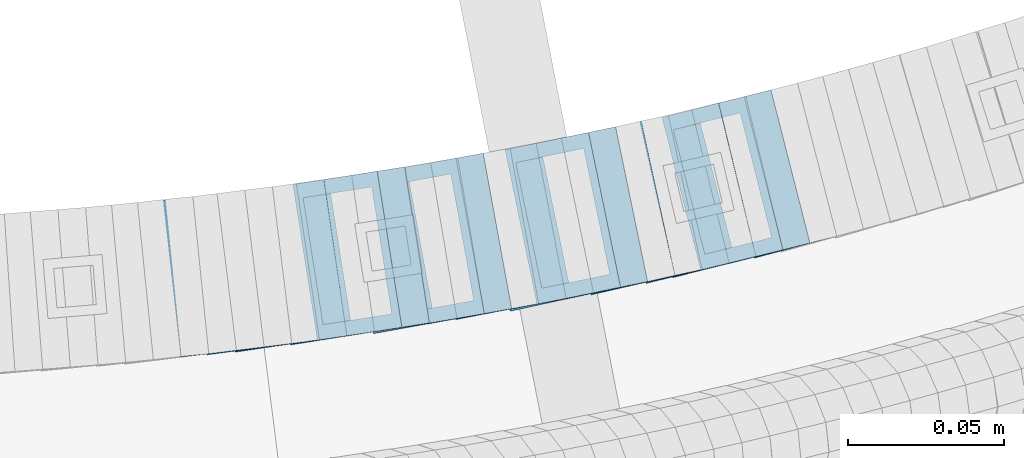
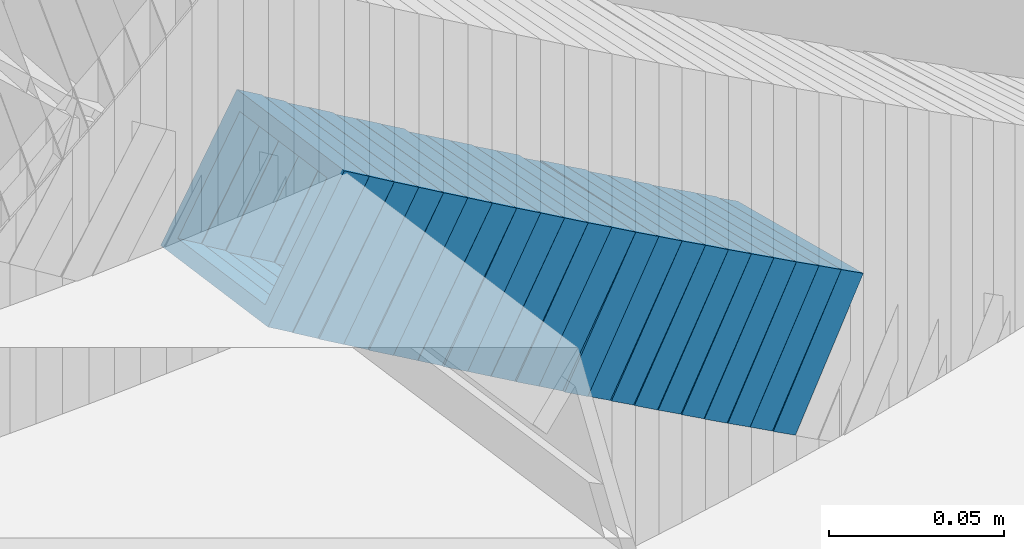
# One storey, part 711 of 975: 22 members.
"""IFC2X3 building model written with IfcOpenShell, lengths in millimetres."""

from ifc_helpers import new_model, si_unit, frame, origin_with_axes, place, context, subcontext, project, spatial, faceted_brep, material, type_object, element, save


model = new_model("IFC2X3")

# Units and contexts
model_context = context("Model", 3, precision=1e-05, world=origin_with_axes())
body_context = subcontext(model_context, "Body", "Model", "MODEL_VIEW")
ifc_project = project(units=[si_unit("LENGTHUNIT", "METRE", prefix="MILLI"), si_unit("AREAUNIT", "SQUARE_METRE"), si_unit("VOLUMEUNIT", "CUBIC_METRE"), si_unit("MASSUNIT", "GRAM", prefix="KILO"), si_unit("TIMEUNIT", "SECOND"), si_unit("PLANEANGLEUNIT", "RADIAN"), si_unit("SOLIDANGLEUNIT", "STERADIAN"), si_unit("THERMODYNAMICTEMPERATUREUNIT", "DEGREE_CELSIUS"), si_unit("LUMINOUSINTENSITYUNIT", "LUMEN")], contexts=[model_context])

# Site, building, storey
site_placement = place(None, origin_with_axes())
site = spatial("IfcSite", under=ifc_project, at=site_placement, CompositionType="ELEMENT")
building_placement = place(site_placement, origin_with_axes())
building = spatial("IfcBuilding", under=site, at=building_placement, Name="Undefined", CompositionType="ELEMENT")
storey_placement = place(building_placement, origin_with_axes())
storey = spatial("IfcBuildingStorey", under=building, at=storey_placement, Name="Undefined", CompositionType="ELEMENT", Elevation=0.0)

# Members
ifc_material = material()
member_type = type_object("IfcMemberType", Name="HSS2X2X.188_TUBES", PredefinedType="NOTDEFINED")
member_1_placement = place(storey_placement, frame((34904.9273180828, 2017.01082653673, 3173.26371378049), z_axis=(0.122662172272845, -0.992448483042474, -1.6880449038581e-10), x_axis=(-0.837575186904508, -0.103520528988198, 0.536424557938842)))
element("IfcMember", 1, at=member_1_placement, inside=storey, type_object=member_type, material=ifc_material, Name="WALL", ObjectType="HSS2X2X.188_TUBES", context=body_context, shape_type="Brep", body=[
    faceted_brep([(0.0, 20.6374999999753, -20.6375000000298), (0.0, -20.6375000000153, -20.6375000000153), (10.6348483769107, -20.637499999988, -20.6374999999825), (10.6348483768415, 20.6374999999734, -20.6375000001026), (0.0, -20.6374999999825, 20.6375000000335), (10.6348483769852, -20.6374999999589, 20.6375000001462), (0.0, 20.6375000000116, 20.6375000000189), (10.6348483769161, 20.6375000000044, 20.6375000000226), (0.0, 25.3999999999724, -25.4000000000342), (0.0, 25.400000000016, 25.4000000000196), (10.6348483769179, 25.4000000000015, 25.4000000000233), (10.6348483768288, 25.3999999999669, -25.4000000001324), (0.0, -25.399999999976, 25.4000000000378), (10.6348483769998, -25.3999999999505, 25.4000000001688), (0.0, -25.400000000016, -25.4000000000196), (10.6348483769107, -25.3999999999887, -25.3999999999833)], [[[0, 1, 2, 3]], [[1, 4, 5, 2]], [[4, 6, 7, 5]], [[6, 0, 3, 7]], [[8, 9, 10, 11]], [[9, 12, 13, 10]], [[12, 14, 15, 13]], [[14, 8, 11, 15]], [[13, 15, 11, 10], [5, 7, 3, 2]], [[14, 12, 9, 8], [6, 4, 1, 0]]]),
])
member_2_placement = place(storey_placement, frame((34913.4145340342, 2018.0047994796, 3167.56307719514), z_axis=(0.133622336118329, -0.991032326057168, -7.08037077856716e-11), x_axis=(-0.832503159066129, -0.112247617008915, 0.542530149043107)))
element("IfcMember", 2, at=member_2_placement, inside=storey, type_object=member_type, material=ifc_material, Name="WALL", ObjectType="HSS2X2X.188_TUBES", context=body_context, shape_type="Brep", body=[
    faceted_brep([(0.0, 20.6374999999753, -20.6375000000298), (0.0, -20.6375000000153, -20.6375000000153), (10.6906501205649, -20.6374999999844, -20.637499999968), (10.690650120574, 20.6375000000098, -20.6374999999716), (0.0, -20.6374999999825, 20.6375000000335), (10.6906501205467, -20.6374999999844, 20.637500000008), (0.0, 20.6375000000116, 20.6375000000189), (10.6906501205558, 20.637500000008, 20.6375000000007), (0.0, 25.3999999999724, -25.4000000000342), (0.0, 25.400000000016, 25.4000000000196), (10.6906501205522, 25.4000000000087, 25.3999999999978), (10.6906501205813, 25.4000000000124, -25.3999999999651), (0.0, -25.399999999976, 25.4000000000378), (10.6906501205431, -25.3999999999833, 25.4000000000051), (0.0, -25.400000000016, -25.4000000000196), (10.6906501205704, -25.3999999999833, -25.3999999999614)], [[[0, 1, 2, 3]], [[1, 4, 5, 2]], [[4, 6, 7, 5]], [[6, 0, 3, 7]], [[8, 9, 10, 11]], [[9, 12, 13, 10]], [[12, 14, 15, 13]], [[14, 8, 11, 15]], [[13, 15, 11, 10], [5, 7, 3, 2]], [[14, 12, 9, 8], [6, 4, 1, 0]]]),
])
member_3_placement = place(storey_placement, frame((34921.9966781385, 2019.09855426591, 3161.81381643288), z_axis=(0.146141233668561, -0.989263736231057, 2.31734247790882e-10), x_axis=(-0.83293605783804, -0.123047371976067, 0.539515400895108)))
element("IfcMember", 3, at=member_3_placement, inside=storey, type_object=member_type, material=ifc_material, Name="WALL", ObjectType="HSS2X2X.188_TUBES", context=body_context, shape_type="Brep", body=[
    faceted_brep([(0.0, 20.6374999999753, -20.6375000000298), (0.0, -20.6375000000153, -20.6375000000153), (10.5744976239494, -20.6375000000207, -20.6375000000335), (10.5744976239657, 20.6375000000098, -20.637500000008), (0.0, -20.6374999999825, 20.6375000000335), (10.5744976239639, -20.6375000000244, 20.6374999999753), (0.0, 20.6375000000116, 20.6375000000189), (10.5744976239803, 20.6374999999989, 20.6374999999935), (0.0, 25.3999999999724, -25.4000000000342), (0.0, 25.400000000016, 25.4000000000196), (10.5744976239857, 25.4000000000051, 25.4000000000015), (10.5744976239675, 25.4000000000124, -25.4000000000051), (0.0, -25.399999999976, 25.4000000000378), (10.5744976239639, -25.4000000000287, 25.3999999999724), (0.0, -25.400000000016, -25.4000000000196), (10.5744976239494, -25.4000000000215, -25.4000000000378)], [[[0, 1, 2, 3]], [[1, 4, 5, 2]], [[4, 6, 7, 5]], [[6, 0, 3, 7]], [[8, 9, 10, 11]], [[9, 12, 13, 10]], [[12, 14, 15, 13]], [[14, 8, 11, 15]], [[13, 15, 11, 10], [5, 7, 3, 2]], [[14, 12, 9, 8], [6, 4, 1, 0]]]),
])
member_4_placement = place(storey_placement, frame((34930.8733920771, 2020.4176887732, 3156.05336678836), z_axis=(0.144533690154451, -0.98949987994458, -1.03716956800781e-10), x_axis=(-0.831594134245589, -0.121468806035883, 0.54193775016006)))
element("IfcMember", 4, at=member_4_placement, inside=storey, type_object=member_type, material=ifc_material, Name="WALL", ObjectType="HSS2X2X.188_TUBES", context=body_context, shape_type="Brep", body=[
    faceted_brep([(0.0, 20.6374999999753, -20.6375000000298), (0.0, -20.6375000000153, -20.6375000000153), (10.6985980389491, -20.6375000000317, -20.6375000000698), (10.6985980389982, 20.6375000000116, -20.6374999999643), (0.0, -20.6374999999825, 20.6375000000335), (10.6985980389818, -20.6374999999989, 20.6374999999789), (0.0, 20.6375000000116, 20.6375000000189), (10.6985980390309, 20.6375000000407, 20.6375000000808), (0.0, 25.3999999999724, -25.4000000000342), (0.0, 25.400000000016, 25.4000000000196), (10.6985980390382, 25.4000000000487, 25.4000000000997), (10.6985980390036, 25.4000000000142, -25.3999999999542), (0.0, -25.399999999976, 25.4000000000378), (10.6985980389763, -25.4000000000033, 25.3999999999724), (0.0, -25.400000000016, -25.4000000000196), (10.6985980389418, -25.400000000036, -25.4000000000851)], [[[0, 1, 2, 3]], [[1, 4, 5, 2]], [[4, 6, 7, 5]], [[6, 0, 3, 7]], [[8, 9, 10, 11]], [[9, 12, 13, 10]], [[12, 14, 15, 13]], [[14, 8, 11, 15]], [[13, 15, 11, 10], [5, 7, 3, 2]], [[14, 12, 9, 8], [6, 4, 1, 0]]]),
])
member_5_placement = place(storey_placement, frame((34939.4573510366, 2021.60801269731, 3150.30322446153), z_axis=(0.157115048787899, -0.987580306326719, 1.66826794156805e-10), x_axis=(-0.831930478100311, -0.132352576015964, 0.538864060064991)))
element("IfcMember", 5, at=member_5_placement, inside=storey, type_object=member_type, material=ifc_material, Name="WALL", ObjectType="HSS2X2X.188_TUBES", context=body_context, shape_type="Brep", body=[
    faceted_brep([(0.0, 20.6374999999753, -20.6375000000298), (0.0, -20.6375000000153, -20.6375000000153), (10.5806427026419, -20.6374999999607, -20.6374999999316), (10.5806427026473, 20.6375000000444, -20.6374999999207), (0.0, -20.6374999999825, 20.6375000000335), (10.5806427025509, -20.6375000000207, 20.6374999999643), (0.0, 20.6375000000116, 20.6375000000189), (10.5806427025545, 20.6374999999862, 20.6374999999716), (0.0, 25.3999999999724, -25.4000000000342), (0.0, 25.400000000016, 25.4000000000196), (10.5806427025436, 25.3999999999796, 25.3999999999614), (10.5806427026582, 25.4000000000542, -25.3999999999105), (0.0, -25.399999999976, 25.4000000000378), (10.5806427025418, -25.4000000000287, 25.3999999999542), (0.0, -25.400000000016, -25.4000000000196), (10.5806427026528, -25.3999999999542, -25.3999999999178)], [[[0, 1, 2, 3]], [[1, 4, 5, 2]], [[4, 6, 7, 5]], [[6, 0, 3, 7]], [[8, 9, 10, 11]], [[9, 12, 13, 10]], [[12, 14, 15, 13]], [[14, 8, 11, 15]], [[13, 15, 11, 10], [5, 7, 3, 2]], [[14, 12, 9, 8], [6, 4, 1, 0]]]),
])
member_6_placement = place(storey_placement, frame((34948.3362475854, 2023.02889458686, 3144.54293197295), z_axis=(0.155392574622674, -0.987852796600858, 2.00030626729131e-10), x_axis=(-0.83061572370479, -0.13065865295357, 0.541300134807601)))
element("IfcMember", 6, at=member_6_placement, inside=storey, type_object=member_type, material=ifc_material, Name="WALL", ObjectType="HSS2X2X.188_TUBES", context=body_context, shape_type="Brep", body=[
    faceted_brep([(0.0, 20.6374999999753, -20.6375000000298), (0.0, -20.6375000000153, -20.6375000000153), (10.7093417165161, -20.637499999968, -20.6374999999534), (10.709341716436, 20.6374999999898, -20.6375000000116), (0.0, -20.6374999999825, 20.6375000000335), (10.7093417164688, -20.6374999999971, 20.6375000000153), (0.0, 20.6375000000116, 20.6375000000189), (10.7093417163924, 20.6374999999643, 20.6374999999571), (0.0, 25.3999999999724, -25.4000000000342), (0.0, 25.400000000016, 25.4000000000196), (10.7093417163815, 25.3999999999542, 25.3999999999469), (10.7093417164288, 25.3999999999869, -25.4000000000196), (0.0, -25.399999999976, 25.4000000000378), (10.7093417164724, -25.3999999999942, 25.4000000000196), (0.0, -25.400000000016, -25.4000000000196), (10.709341716527, -25.3999999999578, -25.3999999999432)], [[[0, 1, 2, 3]], [[1, 4, 5, 2]], [[4, 6, 7, 5]], [[6, 0, 3, 7]], [[8, 9, 10, 11]], [[9, 12, 13, 10]], [[12, 14, 15, 13]], [[14, 8, 11, 15]], [[13, 15, 11, 10], [5, 7, 3, 2]], [[14, 12, 9, 8], [6, 4, 1, 0]]]),
])
member_7_placement = place(storey_placement, frame((34957.1573510366, 2024.4080126973, 3138.80322446153), z_axis=(0.157115048787899, -0.987580306326719, 1.66826794156805e-10), x_axis=(-0.831930478100311, -0.132352576015964, 0.538864060064991)))
element("IfcMember", 7, at=member_7_placement, inside=storey, type_object=member_type, material=ifc_material, Name="WALL", ObjectType="HSS2X2X.188_TUBES", context=body_context, shape_type="Brep", body=[
    faceted_brep([(0.0, 20.6374999999753, -20.6375000000298), (0.0, -20.6375000000153, -20.6375000000153), (10.5806427026419, -20.6374999999607, -20.6374999999316), (10.5806427026473, 20.6375000000444, -20.6374999999207), (0.0, -20.6374999999825, 20.6375000000335), (10.5806427025509, -20.6375000000207, 20.6374999999643), (0.0, 20.6375000000116, 20.6375000000189), (10.5806427025545, 20.6374999999862, 20.6374999999716), (0.0, 25.3999999999724, -25.4000000000342), (0.0, 25.400000000016, 25.4000000000196), (10.5806427025436, 25.3999999999796, 25.3999999999614), (10.5806427026582, 25.4000000000542, -25.3999999999105), (0.0, -25.399999999976, 25.4000000000378), (10.5806427025418, -25.4000000000287, 25.3999999999542), (0.0, -25.400000000016, -25.4000000000196), (10.5806427026528, -25.3999999999542, -25.3999999999178)], [[[0, 1, 2, 3]], [[1, 4, 5, 2]], [[4, 6, 7, 5]], [[6, 0, 3, 7]], [[8, 9, 10, 11]], [[9, 12, 13, 10]], [[12, 14, 15, 13]], [[14, 8, 11, 15]], [[13, 15, 11, 10], [5, 7, 3, 2]], [[14, 12, 9, 8], [6, 4, 1, 0]]]),
])
member_8_placement = place(storey_placement, frame((34965.4911294186, 2025.62233257046, 3133.0798872962), z_axis=(0.178885438594422, -0.983869910028191, -3.6949131754227e-10), x_axis=(-0.829708833093973, -0.150856152017093, 0.537425040060876)))
element("IfcMember", 8, at=member_8_placement, inside=storey, type_object=member_type, material=ifc_material, Name="WALL", ObjectType="HSS2X2X.188_TUBES", context=body_context, shape_type="Brep", body=[
    faceted_brep([(0.0, 20.6374999999753, -20.6375000000298), (0.0, -20.6375000000153, -20.6375000000153), (10.6061303028146, -20.6374999999571, -20.6374999999643), (10.6061303027491, 20.6374999999971, -20.6375000000007), (0.0, -20.6374999999825, 20.6375000000335), (10.6061303027855, -20.6374999999825, 20.6375000000116), (0.0, 20.6375000000116, 20.6375000000189), (10.6061303027236, 20.637499999968, 20.6374999999716), (0.0, 25.3999999999724, -25.4000000000342), (0.0, 25.400000000016, 25.4000000000196), (10.6061303027163, 25.3999999999651, 25.3999999999651), (10.6061303027454, 25.3999999999942, -25.4000000000051), (0.0, -25.399999999976, 25.4000000000378), (10.6061303027891, -25.3999999999796, 25.4000000000124), (0.0, -25.400000000016, -25.4000000000196), (10.6061303028182, -25.3999999999505, -25.3999999999542)], [[[0, 1, 2, 3]], [[1, 4, 5, 2]], [[4, 6, 7, 5]], [[6, 0, 3, 7]], [[8, 9, 10, 11]], [[9, 12, 13, 10]], [[12, 14, 15, 13]], [[14, 8, 11, 15]], [[13, 15, 11, 10], [5, 7, 3, 2]], [[14, 12, 9, 8], [6, 4, 1, 0]]]),
])
member_9_placement = place(storey_placement, frame((34974.1248319169, 2027.19209666106, 3127.38854519298), z_axis=(0.178885438594422, -0.983869910028191, -3.6949131754227e-10), x_axis=(-0.825499965844293, -0.150090902971678, 0.544079522897359)))
element("IfcMember", 9, at=member_9_placement, inside=storey, type_object=member_type, material=ifc_material, Name="WALL", ObjectType="HSS2X2X.188_TUBES", context=body_context, shape_type="Brep", body=[
    faceted_brep([(0.0, 20.6374999999753, -20.6375000000298), (0.0, -20.6375000000153, -20.6375000000153), (10.6625512894789, -20.6374999999625, -20.6374999999389), (10.6625512893879, 20.6374999999789, -20.6375000000371), (0.0, -20.6374999999825, 20.6375000000335), (10.6625512894352, -20.6374999999989, 20.6375000000153), (0.0, 20.6375000000116, 20.6375000000189), (10.6625512893443, 20.6374999999443, 20.6374999999134), (0.0, 25.3999999999724, -25.4000000000342), (0.0, 25.400000000016, 25.4000000000196), (10.6625512893297, 25.3999999999342, 25.3999999998996), (10.6625512893916, 25.399999999976, -25.4000000000415), (0.0, -25.399999999976, 25.4000000000378), (10.6625512894389, -25.399999999996, 25.400000000016), (0.0, -25.400000000016, -25.4000000000196), (10.6625512894971, -25.3999999999523, -25.3999999999214)], [[[0, 1, 2, 3]], [[1, 4, 5, 2]], [[4, 6, 7, 5]], [[6, 0, 3, 7]], [[8, 9, 10, 11]], [[9, 12, 13, 10]], [[12, 14, 15, 13]], [[14, 8, 11, 15]], [[13, 15, 11, 10], [5, 7, 3, 2]], [[14, 12, 9, 8], [6, 4, 1, 0]]]),
])
member_10_placement = place(storey_placement, frame((34982.8399039991, 2028.76650607231, 3121.64873405642), z_axis=(0.180874694294915, -0.983506148920138, -1.96205746760825e-10), x_axis=(-0.826736273706261, -0.152043452945969, 0.541654799807547)))
element("IfcMember", 10, at=member_10_placement, inside=storey, type_object=member_type, material=ifc_material, Name="WALL", ObjectType="HSS2X2X.188_TUBES", context=body_context, shape_type="Brep", body=[
    faceted_brep([(0.0, 20.6374999999753, -20.6375000000298), (0.0, -20.6375000000153, -20.6375000000153), (10.5190303735253, -20.6375000000171, -20.6375000000444), (10.5190303734962, 20.6374999999607, -20.6375000000808), (0.0, -20.6374999999825, 20.6375000000335), (10.5190303735744, -20.6374999999844, 20.6375000000407), (0.0, 20.6375000000116, 20.6375000000189), (10.5190303735435, 20.6374999999916, 20.6375000000044), (0.0, 25.3999999999724, -25.4000000000342), (0.0, 25.400000000016, 25.4000000000196), (10.5190303735435, 25.3999999999942, 25.4000000000124), (10.5190303734835, 25.3999999999523, -25.4000000000924), (0.0, -25.399999999976, 25.4000000000378), (10.5190303735853, -25.399999999976, 25.400000000056), (0.0, -25.400000000016, -25.4000000000196), (10.5190303735235, -25.4000000000196, -25.4000000000451)], [[[0, 1, 2, 3]], [[1, 4, 5, 2]], [[4, 6, 7, 5]], [[6, 0, 3, 7]], [[8, 9, 10, 11]], [[9, 12, 13, 10]], [[12, 14, 15, 13]], [[14, 8, 11, 15]], [[13, 15, 11, 10], [5, 7, 3, 2]], [[14, 12, 9, 8], [6, 4, 1, 0]]]),
])
member_11_placement = place(storey_placement, frame((34991.564306008, 2030.3274548375, 3115.86716837124), z_axis=(0.189674976082606, -0.981846934836618, -7.12880137143657e-11), x_axis=(-0.828494490235645, -0.160050072045518, 0.536638476152618)))
element("IfcMember", 11, at=member_11_placement, inside=storey, type_object=member_type, material=ifc_material, Name="WALL", ObjectType="HSS2X2X.188_TUBES", context=body_context, shape_type="Brep", body=[
    faceted_brep([(0.0, 20.6374999999753, -20.6375000000298), (0.0, -20.6375000000153, -20.6375000000153), (10.6216759506497, -20.637499999968, -20.6374999999534), (10.6216759506497, 20.6375000000262, -20.6374999999643), (0.0, -20.6374999999825, 20.6375000000335), (10.6216759506169, -20.6374999999935, 20.637500000008), (0.0, 20.6375000000116, 20.6375000000189), (10.6216759506242, 20.6375000000007, 20.6374999999971), (0.0, 25.3999999999724, -25.4000000000342), (0.0, 25.400000000016, 25.4000000000196), (10.6216759506169, 25.3999999999978, 25.3999999999869), (10.6216759506533, 25.4000000000269, -25.3999999999614), (0.0, -25.399999999976, 25.4000000000378), (10.6216759506242, -25.3999999999942, 25.4000000000051), (0.0, -25.400000000016, -25.4000000000196), (10.6216759506569, -25.3999999999614, -25.3999999999432)], [[[0, 1, 2, 3]], [[1, 4, 5, 2]], [[4, 6, 7, 5]], [[6, 0, 3, 7]], [[8, 9, 10, 11]], [[9, 12, 13, 10]], [[12, 14, 15, 13]], [[14, 8, 11, 15]], [[13, 15, 11, 10], [5, 7, 3, 2]], [[14, 12, 9, 8], [6, 4, 1, 0]]]),
])
member_12_placement = place(storey_placement, frame((35000.198392797, 2031.99540342173, 3110.17557518153), z_axis=(0.189674976082606, -0.981846934836618, -7.12880137143657e-11), x_axis=(-0.824303982314684, -0.159240542060785, 0.543291261207413)))
element("IfcMember", 12, at=member_12_placement, inside=storey, type_object=member_type, material=ifc_material, Name="WALL", ObjectType="HSS2X2X.188_TUBES", context=body_context, shape_type="Brep", body=[
    faceted_brep([(0.0, 20.6374999999753, -20.6375000000298), (0.0, -20.6375000000153, -20.6375000000153), (10.6831643251735, -20.6375000000498, -20.6375000000953), (10.6831643252044, 20.637499999988, -20.6375000000226), (0.0, -20.6374999999825, 20.6375000000335), (10.6831643251935, -20.6375000000135, 20.637499999968), (0.0, 20.6375000000116, 20.6375000000189), (10.6831643252244, 20.6375000000226, 20.6375000000407), (0.0, 25.3999999999724, -25.4000000000342), (0.0, 25.400000000016, 25.4000000000196), (10.6831643252317, 25.4000000000306, 25.4000000000597), (10.6831643252044, 25.3999999999905, -25.4000000000196), (0.0, -25.399999999976, 25.4000000000378), (10.6831643251917, -25.400000000016, 25.3999999999614), (0.0, -25.400000000016, -25.4000000000196), (10.6831643251644, -25.400000000056, -25.4000000001179)], [[[0, 1, 2, 3]], [[1, 4, 5, 2]], [[4, 6, 7, 5]], [[6, 0, 3, 7]], [[8, 9, 10, 11]], [[9, 12, 13, 10]], [[12, 14, 15, 13]], [[14, 8, 11, 15]], [[13, 15, 11, 10], [5, 7, 3, 2]], [[14, 12, 9, 8], [6, 4, 1, 0]]]),
])
member_13_placement = place(storey_placement, frame((35008.4678805566, 2033.46742696143, 3104.40714083713), z_axis=(0.213361967337347, -0.976973219128312, -1.93437699635979e-10), x_axis=(-0.822844507376832, -0.179701674082304, 0.539105022246868)))
element("IfcMember", 13, at=member_13_placement, inside=storey, type_object=member_type, material=ifc_material, Name="WALL", ObjectType="HSS2X2X.188_TUBES", context=body_context, shape_type="Brep", body=[
    faceted_brep([(0.0, 20.6374999999753, -20.6375000000298), (0.0, -20.6375000000153, -20.6375000000153), (10.5744976239494, -20.6375000000207, -20.6375000000335), (10.5744976239657, 20.6375000000098, -20.637500000008), (0.0, -20.6374999999825, 20.6375000000335), (10.5744976239639, -20.6375000000244, 20.6374999999753), (0.0, 20.6375000000116, 20.6375000000189), (10.5744976239803, 20.6374999999989, 20.6374999999935), (0.0, 25.3999999999724, -25.4000000000342), (0.0, 25.400000000016, 25.4000000000196), (10.5744976239857, 25.4000000000051, 25.4000000000015), (10.5744976239675, 25.4000000000124, -25.4000000000051), (0.0, -25.399999999976, 25.4000000000378), (10.5744976239639, -25.4000000000287, 25.3999999999724), (0.0, -25.400000000016, -25.4000000000196), (10.5744976239494, -25.4000000000215, -25.4000000000378)], [[[0, 1, 2, 3]], [[1, 4, 5, 2]], [[4, 6, 7, 5]], [[6, 0, 3, 7]], [[8, 9, 10, 11]], [[9, 12, 13, 10]], [[12, 14, 15, 13]], [[14, 8, 11, 15]], [[13, 15, 11, 10], [5, 7, 3, 2]], [[14, 12, 9, 8], [6, 4, 1, 0]]]),
])
member_14_placement = place(storey_placement, frame((35017.3875268448, 2035.46820897266, 3098.72169883749), z_axis=(0.20260560413653, -0.979260419486294, -1.52557731780689e-10), x_axis=(-0.824209612871596, -0.170526126973423, 0.539999401915871)))
element("IfcMember", 14, at=member_14_placement, inside=storey, type_object=member_type, material=ifc_material, Name="WALL", ObjectType="HSS2X2X.188_TUBES", context=body_context, shape_type="Brep", body=[
    faceted_brep([(0.0, 20.6374999999753, -20.6375000000298), (0.0, -20.6375000000153, -20.6375000000153), (10.5550935571373, -20.6374999999935, -20.6374999999753), (10.5550935571373, 20.6375000000025, -20.6374999999862), (0.0, -20.6374999999825, 20.6375000000335), (10.5550935571027, -20.6374999999989, 20.6374999999862), (0.0, 20.6375000000116, 20.6375000000189), (10.5550935571027, 20.6374999999953, 20.6374999999716), (0.0, 25.3999999999724, -25.4000000000342), (0.0, 25.400000000016, 25.4000000000196), (10.5550935570991, 25.3999999999924, 25.3999999999651), (10.5550935571373, 25.3999999999996, -25.3999999999905), (0.0, -25.399999999976, 25.4000000000378), (10.5550935571009, -25.3999999999996, 25.3999999999833), (0.0, -25.400000000016, -25.4000000000196), (10.5550935571428, -25.3999999999905, -25.3999999999724)], [[[0, 1, 2, 3]], [[1, 4, 5, 2]], [[4, 6, 7, 5]], [[6, 0, 3, 7]], [[8, 9, 10, 11]], [[9, 12, 13, 10]], [[12, 14, 15, 13]], [[14, 8, 11, 15]], [[13, 15, 11, 10], [5, 7, 3, 2]], [[14, 12, 9, 8], [6, 4, 1, 0]]]),
])
member_15_placement = place(storey_placement, frame((35026.1233713145, 2037.23427206123, 3092.93970037974), z_axis=(0.211045983708842, -0.977476134112934, 1.9527988115442e-10), x_axis=(-0.825863413982785, -0.178311418996282, 0.534934256988867)))
element("IfcMember", 15, at=member_15_placement, inside=storey, type_object=member_type, material=ifc_material, Name="WALL", ObjectType="HSS2X2X.188_TUBES", context=body_context, shape_type="Brep", body=[
    faceted_brep([(0.0, 20.6374999999753, -20.6375000000298), (0.0, -20.6375000000153, -20.6375000000153), (10.6625512894789, -20.6374999999625, -20.6374999999389), (10.6625512893879, 20.6374999999789, -20.6375000000371), (0.0, -20.6374999999825, 20.6375000000335), (10.6625512894352, -20.6374999999989, 20.6375000000153), (0.0, 20.6375000000116, 20.6375000000189), (10.6625512893443, 20.6374999999443, 20.6374999999134), (0.0, 25.3999999999724, -25.4000000000342), (0.0, 25.400000000016, 25.4000000000196), (10.6625512893297, 25.3999999999342, 25.3999999998996), (10.6625512893916, 25.399999999976, -25.4000000000415), (0.0, -25.399999999976, 25.4000000000378), (10.6625512894389, -25.399999999996, 25.400000000016), (0.0, -25.400000000016, -25.4000000000196), (10.6625512894971, -25.3999999999523, -25.3999999999214)], [[[0, 1, 2, 3]], [[1, 4, 5, 2]], [[4, 6, 7, 5]], [[6, 0, 3, 7]], [[8, 9, 10, 11]], [[9, 12, 13, 10]], [[12, 14, 15, 13]], [[14, 8, 11, 15]], [[13, 15, 11, 10], [5, 7, 3, 2]], [[14, 12, 9, 8], [6, 4, 1, 0]]]),
])
member_16_placement = place(storey_placement, frame((35034.2878530275, 2038.92785555438, 3087.30080520356), z_axis=(0.224041298984485, -0.974579651105719, 2.52098288910929e-11), x_axis=(-0.817234718278187, -0.187870050063943, 0.54482314518543)))
element("IfcMember", 16, at=member_16_placement, inside=storey, type_object=member_type, material=ifc_material, Name="WALL", ObjectType="HSS2X2X.188_TUBES", context=body_context, shape_type="Brep", body=[
    faceted_brep([(0.0, 20.6374999999753, -20.6375000000298), (0.0, -20.6375000000153, -20.6375000000153), (10.648004507897, -20.6374999999862, -20.637499999968), (10.6480045078188, 20.6374999999771, -20.6375000000808), (0.0, -20.6374999999825, 20.6375000000335), (10.6480045079406, -20.6374999999698, 20.6375000001062), (0.0, 20.6375000000116, 20.6375000000189), (10.6480045078679, 20.6374999999935, 20.6375000000007), (0.0, 25.3999999999724, -25.4000000000342), (0.0, 25.400000000016, 25.4000000000196), (10.6480045078661, 25.3999999999905, 25.4000000000015), (10.648004507806, 25.3999999999705, -25.4000000000997), (0.0, -25.399999999976, 25.4000000000378), (10.6480045079552, -25.3999999999633, 25.4000000001288), (0.0, -25.400000000016, -25.4000000000196), (10.6480045078988, -25.3999999999814, -25.3999999999651)], [[[0, 1, 2, 3]], [[1, 4, 5, 2]], [[4, 6, 7, 5]], [[6, 0, 3, 7]], [[8, 9, 10, 11]], [[9, 12, 13, 10]], [[12, 14, 15, 13]], [[14, 8, 11, 15]], [[13, 15, 11, 10], [5, 7, 3, 2]], [[14, 12, 9, 8], [6, 4, 1, 0]]]),
])
member_17_placement = place(storey_placement, frame((35043.1526191255, 2040.96573281829, 3081.4919104843), z_axis=(0.224041298984485, -0.974579651105719, 2.52098288910929e-11), x_axis=(-0.821412929796633, -0.188830558953239, 0.538167091866754)))
element("IfcMember", 17, at=member_17_placement, inside=storey, type_object=member_type, material=ifc_material, Name="WALL", ObjectType="HSS2X2X.188_TUBES", context=body_context, shape_type="Brep", body=[
    faceted_brep([(0.0, 20.6374999999753, -20.6375000000298), (0.0, -20.6375000000153, -20.6375000000153), (10.5948100501191, -20.6375000000335, -20.6375000000844), (10.5948100501555, 20.6374999999971, -20.6375000000116), (0.0, -20.6374999999825, 20.6375000000335), (10.5948100501446, -20.6375000000098, 20.6374999999571), (0.0, 20.6375000000116, 20.6375000000189), (10.5948100501828, 20.6375000000189, 20.6375000000298), (0.0, 25.3999999999724, -25.4000000000342), (0.0, 25.400000000016, 25.4000000000196), (10.5948100501919, 25.4000000000251, 25.4000000000451), (10.5948100501591, 25.3999999999978, -25.4000000000051), (0.0, -25.399999999976, 25.4000000000378), (10.5948100501482, -25.4000000000106, 25.3999999999578), (0.0, -25.400000000016, -25.4000000000196), (10.5948100501118, -25.4000000000378, -25.400000000096)], [[[0, 1, 2, 3]], [[1, 4, 5, 2]], [[4, 6, 7, 5]], [[6, 0, 3, 7]], [[8, 9, 10, 11]], [[9, 12, 13, 10]], [[12, 14, 15, 13]], [[14, 8, 11, 15]], [[13, 15, 11, 10], [5, 7, 3, 2]], [[14, 12, 9, 8], [6, 4, 1, 0]]]),
])
member_18_placement = place(storey_placement, frame((35051.3818392069, 2042.7870730036, 3075.84393653876), z_axis=(0.237216214239699, -0.97145687897188, 4.71266957902117e-10), x_axis=(-0.81679113286594, -0.199448996967264, 0.54136156391115)))
element("IfcMember", 18, at=member_18_placement, inside=storey, type_object=member_type, material=ifc_material, Name="WALL", ObjectType="HSS2X2X.188_TUBES", context=body_context, shape_type="Brep", body=[
    faceted_brep([(0.0, 20.6374999999753, -20.6375000000298), (0.0, -20.6375000000153, -20.6375000000153), (10.5290075505945, -20.637499999968, -20.6375000000116), (10.5290075505436, 20.6374999999898, -20.637499999998), (0.0, -20.6374999999825, 20.6375000000335), (10.5290075505145, -20.6375000000189, 20.637500000008), (0.0, 20.6375000000116, 20.6375000000189), (10.5290075504672, 20.6374999999462, 20.6375000000198), (0.0, 25.3999999999724, -25.4000000000342), (0.0, 25.400000000016, 25.4000000000196), (10.5290075504563, 25.399999999936, 25.4000000000224), (10.5290075505472, 25.3999999999869, -25.3999999999987), (0.0, -25.399999999976, 25.4000000000378), (10.5290075505072, -25.4000000000196, 25.4000000000106), (0.0, -25.400000000016, -25.4000000000196), (10.5290075506091, -25.3999999999651, -25.4000000000151)], [[[0, 1, 2, 3]], [[1, 4, 5, 2]], [[4, 6, 7, 5]], [[6, 0, 3, 7]], [[8, 9, 10, 11]], [[9, 12, 13, 10]], [[12, 14, 15, 13]], [[14, 8, 11, 15]], [[13, 15, 11, 10], [5, 7, 3, 2]], [[14, 12, 9, 8], [6, 4, 1, 0]]]),
])
member_19_placement = place(storey_placement, frame((35059.8714902725, 2044.81870958954, 3070.06775487245), z_axis=(0.245156736150922, -0.969483457682403, -1.44891146192094e-10), x_axis=(-0.814222786177679, -0.205895417044928, 0.542815191118444)))
element("IfcMember", 19, at=member_19_placement, inside=storey, type_object=member_type, material=ifc_material, Name="WALL", ObjectType="HSS2X2X.188_TUBES", context=body_context, shape_type="Brep", body=[
    faceted_brep([(0.0, 20.6374999999753, -20.6375000000298), (0.0, -20.6375000000153, -20.6375000000153), (10.6906501205649, -20.6374999999844, -20.637499999968), (10.690650120574, 20.6375000000098, -20.6374999999716), (0.0, -20.6374999999825, 20.6375000000335), (10.6906501205467, -20.6374999999844, 20.637500000008), (0.0, 20.6375000000116, 20.6375000000189), (10.6906501205558, 20.637500000008, 20.6375000000007), (0.0, 25.3999999999724, -25.4000000000342), (0.0, 25.400000000016, 25.4000000000196), (10.6906501205522, 25.4000000000087, 25.3999999999978), (10.6906501205813, 25.4000000000124, -25.3999999999651), (0.0, -25.399999999976, 25.4000000000378), (10.6906501205431, -25.3999999999833, 25.4000000000051), (0.0, -25.400000000016, -25.4000000000196), (10.6906501205704, -25.3999999999833, -25.3999999999614)], [[[0, 1, 2, 3]], [[1, 4, 5, 2]], [[4, 6, 7, 5]], [[6, 0, 3, 7]], [[8, 9, 10, 11]], [[9, 12, 13, 10]], [[12, 14, 15, 13]], [[14, 8, 11, 15]], [[13, 15, 11, 10], [5, 7, 3, 2]], [[14, 12, 9, 8], [6, 4, 1, 0]]]),
])
member_20_placement = place(storey_placement, frame((35068.7352886169, 2047.06012986054, 3064.25949972849), z_axis=(0.245156736150922, -0.969483457682403, -1.44891146192094e-10), x_axis=(-0.818354737867744, -0.206940278966563, 0.536163448913349)))
element("IfcMember", 20, at=member_20_placement, inside=storey, type_object=member_type, material=ifc_material, Name="WALL", ObjectType="HSS2X2X.188_TUBES", context=body_context, shape_type="Brep", body=[
    faceted_brep([(0.0, 20.6374999999753, -20.6375000000298), (0.0, -20.6375000000153, -20.6375000000153), (10.6348483769107, -20.637499999988, -20.6374999999825), (10.6348483768415, 20.6374999999734, -20.6375000001026), (0.0, -20.6374999999825, 20.6375000000335), (10.6348483769852, -20.6374999999589, 20.6375000001462), (0.0, 20.6375000000116, 20.6375000000189), (10.6348483769161, 20.6375000000044, 20.6375000000226), (0.0, 25.3999999999724, -25.4000000000342), (0.0, 25.400000000016, 25.4000000000196), (10.6348483769179, 25.4000000000015, 25.4000000000233), (10.6348483768288, 25.3999999999669, -25.4000000001324), (0.0, -25.399999999976, 25.4000000000378), (10.6348483769998, -25.3999999999505, 25.4000000001688), (0.0, -25.400000000016, -25.4000000000196), (10.6348483769107, -25.3999999999887, -25.3999999999833)], [[[0, 1, 2, 3]], [[1, 4, 5, 2]], [[4, 6, 7, 5]], [[6, 0, 3, 7]], [[8, 9, 10, 11]], [[9, 12, 13, 10]], [[12, 14, 15, 13]], [[14, 8, 11, 15]], [[13, 15, 11, 10], [5, 7, 3, 2]], [[14, 12, 9, 8], [6, 4, 1, 0]]]),
])
member_21_placement = place(storey_placement, frame((35077.1744237299, 2049.18025650527, 3058.62683915836), z_axis=(0.24783324970863, -0.96880270454766, 2.68411440629279e-10), x_axis=(-0.815211655185787, -0.208542516047527, 0.540314701123167)))
element("IfcMember", 21, at=member_21_placement, inside=storey, type_object=member_type, material=ifc_material, Name="WALL", ObjectType="HSS2X2X.188_TUBES", context=body_context, shape_type="Brep", body=[
    faceted_brep([(0.0, 20.6374999999753, -20.6375000000298), (0.0, -20.6375000000153, -20.6375000000153), (10.5531985672587, -20.6374999999916, -20.6375000000007), (10.5531985672878, 20.6375000000062, -20.6374999999789), (0.0, -20.6374999999825, 20.6375000000335), (10.5531985672114, -20.6375000000353, 20.6374999999171), (0.0, 20.6375000000116, 20.6375000000189), (10.5531985672333, 20.6374999999607, 20.6374999999316), (0.0, 25.3999999999724, -25.4000000000342), (0.0, 25.400000000016, 25.4000000000196), (10.5531985672314, 25.399999999956, 25.3999999999251), (10.5531985672933, 25.4000000000106, -25.3999999999724), (0.0, -25.399999999976, 25.4000000000378), (10.5531985672023, -25.4000000000397, 25.3999999999069), (0.0, -25.400000000016, -25.4000000000196), (10.5531985672642, -25.3999999999851, -25.3999999999869)], [[[0, 1, 2, 3]], [[1, 4, 5, 2]], [[4, 6, 7, 5]], [[6, 0, 3, 7]], [[8, 9, 10, 11]], [[9, 12, 13, 10]], [[12, 14, 15, 13]], [[14, 8, 11, 15]], [[13, 15, 11, 10], [5, 7, 3, 2]], [[14, 12, 9, 8], [6, 4, 1, 0]]]),
])
member_22_placement = place(storey_placement, frame((35085.571525633, 2051.27294724953, 3052.90910192296), z_axis=(0.258361740298409, -0.966048244732103, -2.28899807552807e-10), x_axis=(-0.81356848588311, -0.217582269968746, 0.539225624922547)))
element("IfcMember", 22, at=member_22_placement, inside=storey, type_object=member_type, material=ifc_material, Name="WALL", ObjectType="HSS2X2X.188_TUBES", context=body_context, shape_type="Brep", body=[
    faceted_brep([(0.0, 20.6374999999753, -20.6375000000298), (0.0, -20.6375000000153, -20.6375000000153), (10.5744976239494, -20.6375000000207, -20.6375000000335), (10.5744976239657, 20.6375000000098, -20.637500000008), (0.0, -20.6374999999825, 20.6375000000335), (10.5744976239639, -20.6375000000244, 20.6374999999753), (0.0, 20.6375000000116, 20.6375000000189), (10.5744976239803, 20.6374999999989, 20.6374999999935), (0.0, 25.3999999999724, -25.4000000000342), (0.0, 25.400000000016, 25.4000000000196), (10.5744976239857, 25.4000000000051, 25.4000000000015), (10.5744976239675, 25.4000000000124, -25.4000000000051), (0.0, -25.399999999976, 25.4000000000378), (10.5744976239639, -25.4000000000287, 25.3999999999724), (0.0, -25.400000000016, -25.4000000000196), (10.5744976239494, -25.4000000000215, -25.4000000000378)], [[[0, 1, 2, 3]], [[1, 4, 5, 2]], [[4, 6, 7, 5]], [[6, 0, 3, 7]], [[8, 9, 10, 11]], [[9, 12, 13, 10]], [[12, 14, 15, 13]], [[14, 8, 11, 15]], [[13, 15, 11, 10], [5, 7, 3, 2]], [[14, 12, 9, 8], [6, 4, 1, 0]]]),
])

save(model, "model.ifc")
